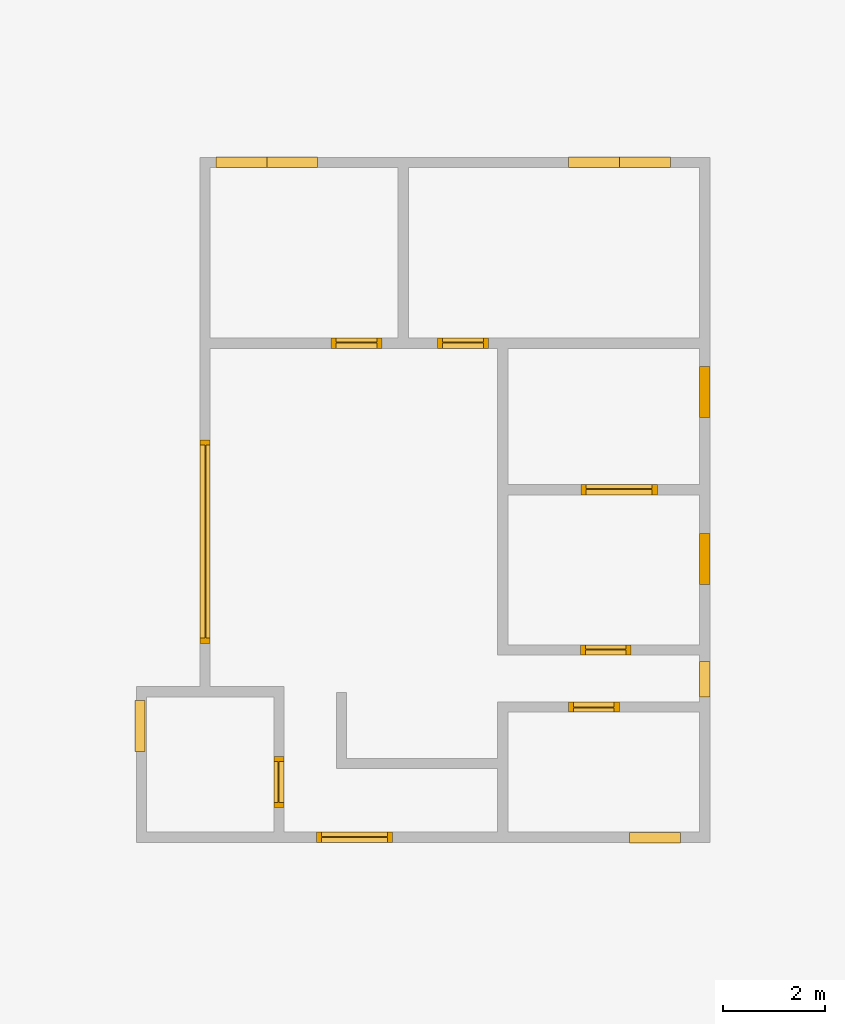
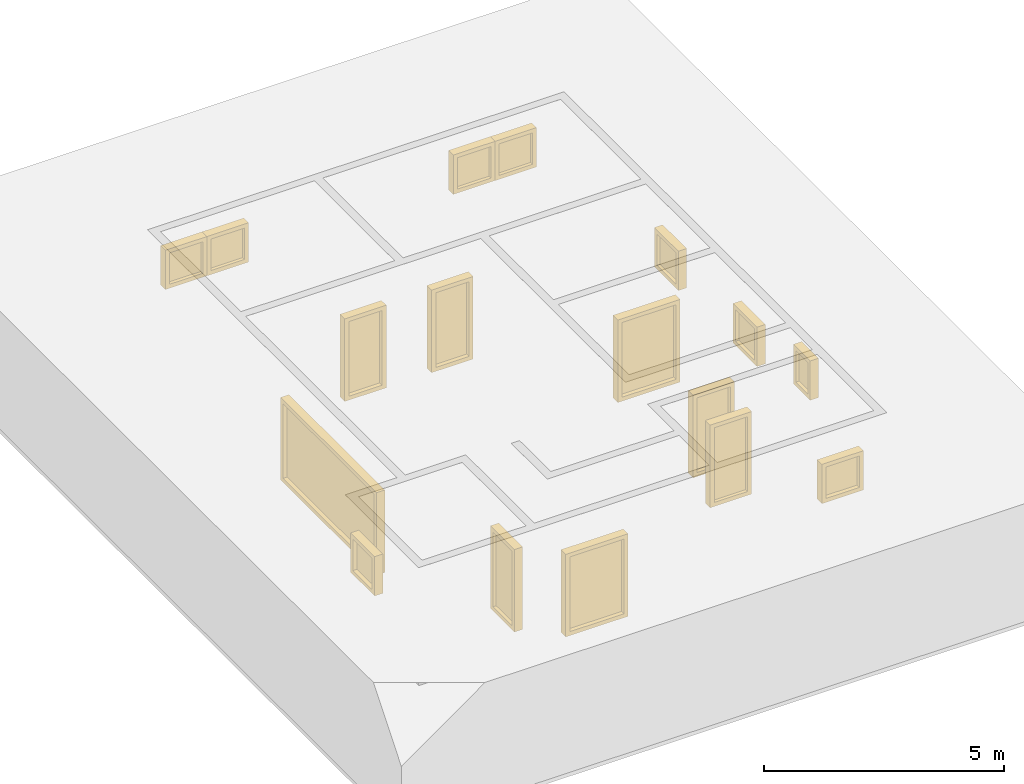
# Not in any storey, part 2 of 2: 17 windows.
"""IFC4 building model written with IfcOpenShell, lengths in metres."""

import ifcopenshell
import ifcopenshell.guid

model = None  # the IFC model being written
_history = None  # IfcOwnerHistory: only IFC2X3 demands one
_inside = {}  # id of a spatial element -> (the spatial element, [elements in it])
_under = {}  # id of a project, library or spatial element -> (it, [spatial elements below it])
_declared = {}  # id of a project -> (the project, [libraries it declares])
_typed = {}  # id of a type object -> (the type object, [elements of that type])
_made_of = {}  # id of a material, layer set ... -> (it, [elements and type objects made of it])


def new_model(schema):
    """Start an empty IFC model of exactly this schema.

    Asked for "IFC4X3", IfcOpenShell would pick the latest addendum, in which some entities
    have other attributes; the version numbers below select the first issue.
    IFC2X3 requires an IfcOwnerHistory on every rooted entity: one is made here for all.
    """
    global model, _history
    if schema == "IFC4X3":
        model = ifcopenshell.file(schema_version=(4, 3, 0, 0))
    else:
        model = ifcopenshell.file(schema=schema)
    _inside.clear()
    _under.clear()
    _declared.clear()
    _typed.clear()
    _made_of.clear()
    _history = None
    if model.schema == "IFC2X3":
        org = make("IfcOrganization", Name="unknown")
        user = make(
            "IfcPersonAndOrganization",
            ThePerson=make("IfcPerson", FamilyName="unknown"),
            TheOrganization=org,
        )
        app = make(
            "IfcApplication",
            ApplicationDeveloper=org,
            Version="unknown",
            ApplicationFullName="unknown",
            ApplicationIdentifier="unknown",
        )
        _history = make(
            "IfcOwnerHistory",
            OwningUser=user,
            OwningApplication=app,
            ChangeAction="ADDED",
            CreationDate=0,
        )
    return model


def make(cls, **values):
    """One entity of the class cls with the attributes given. An attribute that is None is left unset."""
    return model.create_entity(
        cls, **{name: value for name, value in values.items() if value is not None}
    )


def entity(cls, *values):
    """Any entity or typed value of the class cls, its attributes in the order of the schema. None: left unset."""
    e = model.create_entity(cls)
    for i, value in enumerate(values):
        if value is not None:
            e[i] = value
    return e


def rooted(cls, **values):
    """An entity with a GlobalId (a new one), such as an element, a storey or a relation."""
    return make(cls, GlobalId=ifcopenshell.guid.new(), OwnerHistory=_history, **values)


def si_unit(unit_type, name, prefix=None):
    """IfcSIUnit, for example si_unit("LENGTHUNIT", "METRE", prefix="MILLI")."""
    return make("IfcSIUnit", UnitType=unit_type, Prefix=prefix, Name=name)


def converted_unit(unit_type, name, factor, base, dimensions=None, offset=None):
    """IfcConversionBasedUnit, such as the inch: factor (a typed value) times the base unit."""
    return make(
        "IfcConversionBasedUnit"
        if offset is None
        else "IfcConversionBasedUnitWithOffset",
        ConversionOffset=offset,
        Dimensions=None
        if dimensions is None
        else entity("IfcDimensionalExponents", *dimensions),
        UnitType=unit_type,
        Name=name,
        ConversionFactor=make(
            "IfcMeasureWithUnit", ValueComponent=factor, UnitComponent=base
        ),
    )


def assignment(units):
    """IfcUnitAssignment: the units of a project."""
    return None if units is None else make("IfcUnitAssignment", Units=units)


def point(xyz):
    """IfcCartesianPoint."""
    return None if xyz is None else make("IfcCartesianPoint", Coordinates=xyz)


def direction(xyz):
    """IfcDirection."""
    return None if xyz is None else make("IfcDirection", DirectionRatios=xyz)


def frame(location, z_axis=None, x_axis=None):
    """IfcAxis2Placement3D, a coordinate frame: its origin and axes. An axis left out is left unset."""
    return make(
        "IfcAxis2Placement3D",
        Location=point(location),
        Axis=direction(z_axis),
        RefDirection=direction(x_axis),
    )


def origin_with_axes():
    """The frame at (0, 0, 0) with the z axis (0, 0, 1) and the x axis (1, 0, 0) written out."""
    return frame((0.0, 0.0, 0.0), z_axis=(0.0, 0.0, 1.0), x_axis=(1.0, 0.0, 0.0))


def place(relative_to, where):
    """IfcLocalPlacement: puts the frame where relative to a parent placement (None: the world)."""
    return make(
        "IfcLocalPlacement", PlacementRelTo=relative_to, RelativePlacement=where
    )


def context(
    kind, dimensions, precision=None, world=None, true_north=None, identifier=None
):
    """IfcGeometricRepresentationContext, for example the 3D "Model" context."""
    return make(
        "IfcGeometricRepresentationContext",
        ContextIdentifier=identifier,
        ContextType=kind,
        CoordinateSpaceDimension=dimensions,
        Precision=precision,
        WorldCoordinateSystem=world,
        TrueNorth=true_north,
    )


def subcontext(parent, identifier, kind, view, scale=None):
    """IfcGeometricRepresentationSubContext, for example "Body" below "Model"."""
    return make(
        "IfcGeometricRepresentationSubContext",
        ContextIdentifier=identifier,
        ContextType=kind,
        ParentContext=parent,
        TargetScale=scale,
        TargetView=view,
    )


def project(units=None, contexts=None):
    """IfcProject with its units and contexts."""
    return rooted(
        "IfcProject",
        Name="project",
        RepresentationContexts=contexts,
        UnitsInContext=assignment(units),
    )


def spatial(cls, under=None, at=None, **own):
    """A site, building, storey or space (cls), placed at a placement, below another one or the project."""
    s = rooted(cls, ObjectPlacement=at, **own)
    if under is not None:
        _under.setdefault(under.id(), (under, []))[1].append(s)
    return s


def faces_of(points, faces, orient=None, outer=None):
    """IfcFace entities. A face is a list of loops; a loop is a list of indices into points, from 0.

    orient and outer hold one flag for each loop. By default every Orientation is true, the
    first loop of a face is its IfcFaceOuterBound and the others are IfcFaceBound.
    """
    made = []
    for i, loops in enumerate(faces):
        bounds = []
        for j, loop in enumerate(loops):
            is_outer = j == 0 if outer is None else outer[i][j]
            bounds.append(
                make(
                    "IfcFaceOuterBound" if is_outer else "IfcFaceBound",
                    Bound=make("IfcPolyLoop", Polygon=[points[k] for k in loop]),
                    Orientation=True if orient is None else orient[i][j],
                )
            )
        made.append(make("IfcFace", Bounds=bounds))
    return made


def faceted_brep(points, faces, orient=None, outer=None, voids=None):
    """IfcFacetedBrep: a solid bounded by flat faces; with voids (closed shells), ...WithVoids."""
    shared = [point(p) for p in points]
    hull = make("IfcClosedShell", CfsFaces=faces_of(shared, faces, orient, outer))
    if voids is None:
        return make("IfcFacetedBrep", Outer=hull)
    return make(
        "IfcFacetedBrepWithVoids",
        Outer=hull,
        Voids=[
            make(cls, CfsFaces=faces_of(shared, fs, o, b)) for cls, fs, o, b in voids
        ],
    )


def shape(context_of_items, identifier, shape_type, items):
    """IfcShapeRepresentation: the items that make up one representation, for example the "Body"."""
    return make(
        "IfcShapeRepresentation",
        ContextOfItems=context_of_items,
        RepresentationIdentifier=identifier,
        RepresentationType=shape_type,
        Items=items,
    )


def made_of(thing, what):
    """Note that an element or type object is made of a material, layer set ...; save() writes the relation."""
    if what is not None:
        _made_of.setdefault(what.id(), (what, []))[1].append(thing)
    return thing


def element(
    cls,
    number,
    at=None,
    inside=None,
    cuts=None,
    type_object=None,
    material=None,
    context=None,
    identifier="Body",
    shape_type=None,
    held_by="IfcProductDefinitionShape",
    body=None,
    shapes=None,
    **own,
):
    """One element of the class cls, such as IfcWall. Its Tag is "e" and its number.

    at: its placement. inside: the storey or other place that contains it. cuts: it is an
    opening in that element (IfcRelVoidsElement). A single representation is given by context,
    identifier, shape_type and body (its items); several are given by shapes. held_by: the class
    of the entity that holds the representations. save() writes the other relations.
    """
    e = rooted(cls, Tag="e%d" % number, ObjectPlacement=at, **own)
    if body is not None:
        shapes = [shape(context, identifier, shape_type, body)]
    if shapes is not None:
        e.Representation = make(held_by, Representations=shapes)
    if inside is not None:
        _inside.setdefault(inside.id(), (inside, []))[1].append(e)
    if cuts is not None:
        rooted(
            "IfcRelVoidsElement", RelatingBuildingElement=cuts, RelatedOpeningElement=e
        )
    if type_object is not None:
        _typed.setdefault(type_object.id(), (type_object, []))[1].append(e)
    return made_of(e, material)


def aggregate(whole, parts):
    """IfcRelAggregates: a whole, such as a stair, and the parts it consists of."""
    return rooted("IfcRelAggregates", RelatingObject=whole, RelatedObjects=parts)


def save(model, path):
    """Write the relations noted so far, then the file.

    IfcRelAggregates (storeys below a building ...), IfcRelContainedInSpatialStructure (elements
    in a storey), IfcRelDefinesByType, IfcRelAssociatesMaterial and IfcRelDeclares: one each for
    every whole, place, type object, material and project.
    """
    for whole, parts in _under.values():
        aggregate(whole, parts)
    for where, things in _inside.values():
        rooted(
            "IfcRelContainedInSpatialStructure",
            RelatedElements=things,
            RelatingStructure=where,
        )
    for kind, things in _typed.values():
        rooted("IfcRelDefinesByType", RelatedObjects=things, RelatingType=kind)
    for what, things in _made_of.values():
        rooted("IfcRelAssociatesMaterial", RelatedObjects=things, RelatingMaterial=what)
    for by, libraries in _declared.values():
        rooted("IfcRelDeclares", RelatingContext=by, RelatedDefinitions=libraries)
    model.write(path)


model = new_model("IFC4")

# Units and contexts
model_context = context("Model", 3, precision=1e-05, world=origin_with_axes(), true_north=direction((0.0, 1.0)))
body_context = subcontext(model_context, "Body", "Model", "MODEL_VIEW")
ifc_project = project(units=[si_unit("LENGTHUNIT", "METRE"), si_unit("AREAUNIT", "SQUARE_METRE"), si_unit("VOLUMEUNIT", "CUBIC_METRE"), converted_unit("PLANEANGLEUNIT", "DEGREE", entity("IfcPlaneAngleMeasure", 0.017453292519943295), si_unit("PLANEANGLEUNIT", "RADIAN"), dimensions=[0, 0, 0, 0, 0, 0, 0])], contexts=[model_context])

# Building
building = spatial("IfcBuilding", Name="002", CompositionType="COMPLEX")

# Windows
placement = place(None, origin_with_axes())
element("IfcWindow", 1, at=placement, inside=building, Name="006", OverallHeight=2100.0, OverallWidth=1000.0, PartitioningType="SINGLE_PANEL", PredefinedType="WINDOW", context=body_context, shape_type="Brep", body=[
    faceted_brep([(2.799520508, -1.01211743164062, 0.0), (2.599520508, -1.01211743164062, 0.0), (2.599520508, -0.012117431640625, 0.0), (2.799520508, -0.012117431640625, 0.0), (2.799520508, -1.01211743164062, 2.1), (2.599520508, -1.01211743164062, 2.1), (2.599520508, -0.012117431640625, 2.1), (2.799520508, -0.012117431640625, 2.1), (2.799520508, -0.112117431640625, 0.1), (2.799520508, -0.912117431640625, 0.1), (2.799520508, -0.912117431640625, 2.0), (2.799520508, -0.112117431640625, 2.0), (2.599520508, -0.912117431640625, 0.1), (2.599520508, -0.112117431640625, 0.1), (2.599520508, -0.112117431640625, 2.0), (2.599520508, -0.912117431640625, 2.0)], [[[0, 1, 2, 3]], [[4, 5, 1, 0]], [[3, 2, 6, 7]], [[0, 3, 7, 4], [8, 9, 10, 11]], [[5, 6, 2, 1], [12, 13, 14, 15]], [[7, 6, 5, 4]], [[8, 13, 12, 9]], [[11, 14, 13, 8]], [[10, 15, 14, 11]], [[9, 12, 15, 10]]]),
    faceted_brep([(2.699520508, -0.912117431640625, 0.1), (2.679520508, -0.912117431640625, 0.1), (2.679520508, -0.112117431640625, 0.1), (2.699520508, -0.112117431640625, 0.1), (2.679520508, -0.112117431640625, 2.0), (2.699520508, -0.112117431640625, 2.0), (2.679520508, -0.912117431640625, 2.0), (2.699520508, -0.912117431640625, 2.0)], [[[0, 1, 2, 3]], [[3, 2, 4, 5]], [[5, 4, 6, 7]], [[7, 6, 1, 0]], [[0, 3, 5, 7]], [[6, 4, 2, 1]]]),
])
element("IfcWindow", 2, at=placement, inside=building, Name="009", OverallHeight=2100.0, OverallWidth=1000.0, PartitioningType="SINGLE_PANEL", PredefinedType="WINDOW", context=body_context, shape_type="Brep", body=[
    faceted_brep([(3.7253876953125, 8.00997583, 0.0), (3.7253876953125, 8.20997583, -4e-17), (4.7253876953125, 8.20997583, -4e-17), (4.7253876953125, 8.00997583, 0.0), (3.7253876953125, 8.00997583, 2.1), (3.7253876953125, 8.20997583, 2.1), (4.7253876953125, 8.20997583, 2.1), (4.7253876953125, 8.00997583, 2.1), (4.6253876953125, 8.00997583, 0.1), (3.8253876953125, 8.00997583, 0.1), (3.8253876953125, 8.00997583, 2.0), (4.6253876953125, 8.00997583, 2.0), (3.8253876953125, 8.20997583, 0.1), (4.6253876953125, 8.20997583, 0.1), (4.6253876953125, 8.20997583, 2.0), (3.8253876953125, 8.20997583, 2.0)], [[[0, 1, 2, 3]], [[4, 5, 1, 0]], [[3, 2, 6, 7]], [[0, 3, 7, 4], [8, 9, 10, 11]], [[5, 6, 2, 1], [12, 13, 14, 15]], [[7, 6, 5, 4]], [[8, 13, 12, 9]], [[11, 14, 13, 8]], [[10, 15, 14, 11]], [[9, 12, 15, 10]]]),
    faceted_brep([(3.8253876953125, 8.10997583, 0.1), (3.8253876953125, 8.12997583, 0.1), (4.6253876953125, 8.12997583, 0.1), (4.6253876953125, 8.10997583, 0.1), (4.6253876953125, 8.12997583, 2.0), (4.6253876953125, 8.10997583, 2.0), (3.8253876953125, 8.12997583, 2.0), (3.8253876953125, 8.10997583, 2.0)], [[[0, 1, 2, 3]], [[3, 2, 4, 5]], [[5, 4, 6, 7]], [[7, 6, 1, 0]], [[0, 3, 5, 7]], [[6, 4, 2, 1]]]),
])
element("IfcWindow", 3, at=placement, inside=building, Name="010", OverallHeight=1000.0, OverallWidth=1000.0, PartitioningType="SINGLE_PANEL", PredefinedType="WINDOW", context=body_context, shape_type="Brep", body=[
    faceted_brep([(3.46358325195312, 11.766516357, 1.48285754394531), (3.46358325195312, 11.566516357, 1.48285754394531), (2.46358325195312, 11.566516357, 1.48285754394531), (2.46358325195312, 11.766516357, 1.48285754394531), (3.46358325195312, 11.766516357, 2.48285754394531), (3.46358325195312, 11.566516357, 2.48285754394531), (2.46358325195312, 11.566516357, 2.48285754394531), (2.46358325195312, 11.766516357, 2.48285754394531), (2.56358325195312, 11.766516357, 1.58285754394531), (3.36358325195313, 11.766516357, 1.58285754394531), (3.36358325195313, 11.766516357, 2.38285754394531), (2.56358325195312, 11.766516357, 2.38285754394531), (3.36358325195313, 11.566516357, 1.58285754394531), (2.56358325195312, 11.566516357, 1.58285754394531), (2.56358325195312, 11.566516357, 2.38285754394531), (3.36358325195313, 11.566516357, 2.38285754394531)], [[[0, 1, 2, 3]], [[4, 5, 1, 0]], [[3, 2, 6, 7]], [[0, 3, 7, 4], [8, 9, 10, 11]], [[5, 6, 2, 1], [12, 13, 14, 15]], [[7, 6, 5, 4]], [[8, 13, 12, 9]], [[11, 14, 13, 8]], [[10, 15, 14, 11]], [[9, 12, 15, 10]]]),
    faceted_brep([(3.36358325195313, 11.666516357, 1.58285754394531), (3.36358325195313, 11.646516357, 1.58285754394531), (2.56358325195312, 11.646516357, 1.58285754394531), (2.56358325195312, 11.666516357, 1.58285754394531), (2.56358325195312, 11.646516357, 2.38285754394531), (2.56358325195312, 11.666516357, 2.38285754394531), (3.36358325195313, 11.646516357, 2.38285754394531), (3.36358325195313, 11.666516357, 2.38285754394531)], [[[0, 1, 2, 3]], [[3, 2, 4, 5]], [[5, 4, 6, 7]], [[7, 6, 1, 0]], [[0, 3, 5, 7]], [[6, 4, 2, 1]]]),
])
element("IfcWindow", 4, at=placement, inside=building, Name="011", OverallHeight=1000.0, OverallWidth=1000.0, PartitioningType="SINGLE_PANEL", PredefinedType="WINDOW", context=body_context, shape_type="Brep", body=[
    faceted_brep([(2.46358325195312, 11.766516357, 1.48285754394531), (2.46358325195312, 11.566516357, 1.48285754394531), (1.46358325195313, 11.566516357, 1.48285754394531), (1.46358325195313, 11.766516357, 1.48285754394531), (2.46358325195312, 11.766516357, 2.48285754394531), (2.46358325195312, 11.566516357, 2.48285754394531), (1.46358325195313, 11.566516357, 2.48285754394531), (1.46358325195313, 11.766516357, 2.48285754394531), (1.56358325195312, 11.766516357, 1.58285754394531), (2.36358325195313, 11.766516357, 1.58285754394531), (2.36358325195313, 11.766516357, 2.38285754394531), (1.56358325195312, 11.766516357, 2.38285754394531), (2.36358325195313, 11.566516357, 1.58285754394531), (1.56358325195312, 11.566516357, 1.58285754394531), (1.56358325195312, 11.566516357, 2.38285754394531), (2.36358325195313, 11.566516357, 2.38285754394531)], [[[0, 1, 2, 3]], [[4, 5, 1, 0]], [[3, 2, 6, 7]], [[0, 3, 7, 4], [8, 9, 10, 11]], [[5, 6, 2, 1], [12, 13, 14, 15]], [[7, 6, 5, 4]], [[8, 13, 12, 9]], [[11, 14, 13, 8]], [[10, 15, 14, 11]], [[9, 12, 15, 10]]]),
    faceted_brep([(2.36358325195313, 11.666516357, 1.58285754394531), (2.36358325195313, 11.646516357, 1.58285754394531), (1.56358325195312, 11.646516357, 1.58285754394531), (1.56358325195312, 11.666516357, 1.58285754394531), (1.56358325195312, 11.646516357, 2.38285754394531), (1.56358325195312, 11.666516357, 2.38285754394531), (2.36358325195313, 11.646516357, 2.38285754394531), (2.36358325195313, 11.666516357, 2.38285754394531)], [[[0, 1, 2, 3]], [[3, 2, 4, 5]], [[5, 4, 6, 7]], [[7, 6, 1, 0]], [[0, 3, 5, 7]], [[6, 4, 2, 1]]]),
])
element("IfcWindow", 5, at=placement, inside=building, Name="012", OverallHeight=1000.0, OverallWidth=1000.0, PartitioningType="SINGLE_PANEL", PredefinedType="WINDOW", context=body_context, shape_type="Brep", body=[
    faceted_brep([(10.394705078125, 11.766516357, 1.477650390625), (10.394705078125, 11.566516357, 1.477650390625), (9.394705078125, 11.566516357, 1.477650390625), (9.394705078125, 11.766516357, 1.477650390625), (10.394705078125, 11.766516357, 2.477650390625), (10.394705078125, 11.566516357, 2.477650390625), (9.394705078125, 11.566516357, 2.477650390625), (9.394705078125, 11.766516357, 2.477650390625), (9.494705078125, 11.766516357, 1.577650390625), (10.294705078125, 11.766516357, 1.577650390625), (10.294705078125, 11.766516357, 2.377650390625), (9.494705078125, 11.766516357, 2.377650390625), (10.294705078125, 11.566516357, 1.577650390625), (9.494705078125, 11.566516357, 1.577650390625), (9.494705078125, 11.566516357, 2.377650390625), (10.294705078125, 11.566516357, 2.377650390625)], [[[0, 1, 2, 3]], [[4, 5, 1, 0]], [[3, 2, 6, 7]], [[0, 3, 7, 4], [8, 9, 10, 11]], [[5, 6, 2, 1], [12, 13, 14, 15]], [[7, 6, 5, 4]], [[8, 13, 12, 9]], [[11, 14, 13, 8]], [[10, 15, 14, 11]], [[9, 12, 15, 10]]]),
    faceted_brep([(10.294705078125, 11.666516357, 1.577650390625), (10.294705078125, 11.646516357, 1.577650390625), (9.494705078125, 11.646516357, 1.577650390625), (9.494705078125, 11.666516357, 1.577650390625), (9.494705078125, 11.646516357, 2.377650390625), (9.494705078125, 11.666516357, 2.377650390625), (10.294705078125, 11.646516357, 2.377650390625), (10.294705078125, 11.666516357, 2.377650390625)], [[[0, 1, 2, 3]], [[3, 2, 4, 5]], [[5, 4, 6, 7]], [[7, 6, 1, 0]], [[0, 3, 5, 7]], [[6, 4, 2, 1]]]),
])
element("IfcWindow", 6, at=placement, inside=building, Name="013", OverallHeight=1000.0, OverallWidth=1000.0, PartitioningType="SINGLE_PANEL", PredefinedType="WINDOW", context=body_context, shape_type="Brep", body=[
    faceted_brep([(9.394705078125, 11.766516357, 1.477650390625), (9.394705078125, 11.566516357, 1.477650390625), (8.394705078125, 11.566516357, 1.477650390625), (8.394705078125, 11.766516357, 1.477650390625), (9.394705078125, 11.766516357, 2.477650390625), (9.394705078125, 11.566516357, 2.477650390625), (8.394705078125, 11.566516357, 2.477650390625), (8.394705078125, 11.766516357, 2.477650390625), (8.494705078125, 11.766516357, 1.577650390625), (9.294705078125, 11.766516357, 1.577650390625), (9.294705078125, 11.766516357, 2.377650390625), (8.494705078125, 11.766516357, 2.377650390625), (9.294705078125, 11.566516357, 1.577650390625), (8.494705078125, 11.566516357, 1.577650390625), (8.494705078125, 11.566516357, 2.377650390625), (9.294705078125, 11.566516357, 2.377650390625)], [[[0, 1, 2, 3]], [[4, 5, 1, 0]], [[3, 2, 6, 7]], [[0, 3, 7, 4], [8, 9, 10, 11]], [[5, 6, 2, 1], [12, 13, 14, 15]], [[7, 6, 5, 4]], [[8, 13, 12, 9]], [[11, 14, 13, 8]], [[10, 15, 14, 11]], [[9, 12, 15, 10]]]),
    faceted_brep([(9.294705078125, 11.666516357, 1.577650390625), (9.294705078125, 11.646516357, 1.577650390625), (8.494705078125, 11.646516357, 1.577650390625), (8.494705078125, 11.666516357, 1.577650390625), (8.494705078125, 11.646516357, 2.377650390625), (8.494705078125, 11.666516357, 2.377650390625), (9.294705078125, 11.646516357, 2.377650390625), (9.294705078125, 11.666516357, 2.377650390625)], [[[0, 1, 2, 3]], [[3, 2, 4, 5]], [[5, 4, 6, 7]], [[7, 6, 1, 0]], [[0, 3, 5, 7]], [[6, 4, 2, 1]]]),
])
element("IfcWindow", 7, at=placement, inside=building, Name="014", OverallHeight=1000.0, OverallWidth=1000.0, PartitioningType="SINGLE_PANEL", PredefinedType="WINDOW", context=body_context, shape_type="Brep", body=[
    faceted_brep([(-0.127817366, 1.09050927734375, 1.20494030761719), (0.072182634, 1.09050927734375, 1.20494030761719), (0.072182634, 0.09050927734375, 1.20494030761719), (-0.127817366, 0.09050927734375, 1.20494030761719), (-0.127817366, 1.09050927734375, 2.20494030761719), (0.072182634, 1.09050927734375, 2.20494030761719), (0.072182634, 0.09050927734375, 2.20494030761719), (-0.127817366, 0.09050927734375, 2.20494030761719), (-0.127817366, 0.19050927734375, 1.30494030761719), (-0.127817366, 0.99050927734375, 1.30494030761719), (-0.127817366, 0.99050927734375, 2.10494030761719), (-0.127817366, 0.19050927734375, 2.10494030761719), (0.072182634, 0.99050927734375, 1.30494030761719), (0.072182634, 0.19050927734375, 1.30494030761719), (0.072182634, 0.19050927734375, 2.10494030761719), (0.072182634, 0.99050927734375, 2.10494030761719)], [[[0, 1, 2, 3]], [[4, 5, 1, 0]], [[3, 2, 6, 7]], [[0, 3, 7, 4], [8, 9, 10, 11]], [[5, 6, 2, 1], [12, 13, 14, 15]], [[7, 6, 5, 4]], [[8, 13, 12, 9]], [[11, 14, 13, 8]], [[10, 15, 14, 11]], [[9, 12, 15, 10]]]),
    faceted_brep([(-0.027817366, 0.99050927734375, 1.30494030761719), (-0.00781736599999999, 0.99050927734375, 1.30494030761719), (-0.00781736599999999, 0.19050927734375, 1.30494030761719), (-0.027817366, 0.19050927734375, 1.30494030761719), (-0.00781736599999999, 0.19050927734375, 2.10494030761719), (-0.027817366, 0.19050927734375, 2.10494030761719), (-0.00781736599999999, 0.99050927734375, 2.10494030761719), (-0.027817366, 0.99050927734375, 2.10494030761719)], [[[0, 1, 2, 3]], [[3, 2, 4, 5]], [[5, 4, 6, 7]], [[7, 6, 1, 0]], [[0, 3, 5, 7]], [[6, 4, 2, 1]]]),
])
element("IfcWindow", 8, at=placement, inside=building, Name="015", OverallHeight=1000.0, OverallWidth=1000.0, PartitioningType="SINGLE_PANEL", PredefinedType="WINDOW", context=body_context, shape_type="Brep", body=[
    faceted_brep([(9.595484375, -1.709431519, 1.23817114257812), (9.595484375, -1.509431519, 1.23817114257812), (10.595484375, -1.509431519, 1.23817114257812), (10.595484375, -1.709431519, 1.23817114257812), (9.595484375, -1.709431519, 2.23817114257813), (9.595484375, -1.509431519, 2.23817114257813), (10.595484375, -1.509431519, 2.23817114257813), (10.595484375, -1.709431519, 2.23817114257813), (10.495484375, -1.709431519, 1.33817114257813), (9.695484375, -1.709431519, 1.33817114257813), (9.695484375, -1.709431519, 2.13817114257813), (10.495484375, -1.709431519, 2.13817114257813), (9.695484375, -1.509431519, 1.33817114257813), (10.495484375, -1.509431519, 1.33817114257813), (10.495484375, -1.509431519, 2.13817114257813), (9.695484375, -1.509431519, 2.13817114257813)], [[[0, 1, 2, 3]], [[4, 5, 1, 0]], [[3, 2, 6, 7]], [[0, 3, 7, 4], [8, 9, 10, 11]], [[5, 6, 2, 1], [12, 13, 14, 15]], [[7, 6, 5, 4]], [[8, 13, 12, 9]], [[11, 14, 13, 8]], [[10, 15, 14, 11]], [[9, 12, 15, 10]]]),
    faceted_brep([(9.695484375, -1.609431519, 1.33817114257813), (9.695484375, -1.589431519, 1.33817114257813), (10.495484375, -1.589431519, 1.33817114257813), (10.495484375, -1.609431519, 1.33817114257813), (10.495484375, -1.589431519, 2.13817114257813), (10.495484375, -1.609431519, 2.13817114257813), (9.695484375, -1.589431519, 2.13817114257813), (9.695484375, -1.609431519, 2.13817114257813)], [[[0, 1, 2, 3]], [[3, 2, 4, 5]], [[5, 4, 6, 7]], [[7, 6, 1, 0]], [[0, 3, 5, 7]], [[6, 4, 2, 1]]]),
])
element("IfcWindow", 9, at=placement, inside=building, Name="017", OverallHeight=2100.0, OverallWidth=1500.0, PartitioningType="SINGLE_PANEL", PredefinedType="WINDOW", context=body_context, shape_type="Brep", body=[
    faceted_brep([(8.63672265625, 5.131109375, 0.0), (8.63672265625, 5.331109375, -4e-17), (10.13672265625, 5.331109375, -4e-17), (10.13672265625, 5.131109375, 0.0), (8.63672265625, 5.131109375, 2.1), (8.63672265625, 5.331109375, 2.1), (10.13672265625, 5.331109375, 2.1), (10.13672265625, 5.131109375, 2.1), (10.03672265625, 5.131109375, 0.1), (8.73672265625, 5.131109375, 0.1), (8.73672265625, 5.131109375, 2.0), (10.03672265625, 5.131109375, 2.0), (8.73672265625, 5.331109375, 0.1), (10.03672265625, 5.331109375, 0.1), (10.03672265625, 5.331109375, 2.0), (8.73672265625, 5.331109375, 2.0)], [[[0, 1, 2, 3]], [[4, 5, 1, 0]], [[3, 2, 6, 7]], [[0, 3, 7, 4], [8, 9, 10, 11]], [[5, 6, 2, 1], [12, 13, 14, 15]], [[7, 6, 5, 4]], [[8, 13, 12, 9]], [[11, 14, 13, 8]], [[10, 15, 14, 11]], [[9, 12, 15, 10]]]),
    faceted_brep([(8.73672265625, 5.231109375, 0.1), (8.73672265625, 5.251109375, 0.1), (10.03672265625, 5.251109375, 0.1), (10.03672265625, 5.231109375, 0.1), (10.03672265625, 5.251109375, 2.0), (10.03672265625, 5.231109375, 2.0), (8.73672265625, 5.251109375, 2.0), (8.73672265625, 5.231109375, 2.0)], [[[0, 1, 2, 3]], [[3, 2, 4, 5]], [[5, 4, 6, 7]], [[7, 6, 1, 0]], [[0, 3, 5, 7]], [[6, 4, 2, 1]]]),
])
element("IfcWindow", 10, at=placement, inside=building, Name="018", OverallHeight=1000.0, OverallWidth=1000.0, PartitioningType="SINGLE_PANEL", PredefinedType="WINDOW", context=body_context, shape_type="Brep", body=[
    faceted_brep([(11.170980469, 3.37278393554688, 1.16492016601562), (10.970980469, 3.37278393554688, 1.16492016601562), (10.970980469, 4.37278393554687, 1.16492016601562), (11.170980469, 4.37278393554687, 1.16492016601562), (11.170980469, 3.37278393554688, 2.16492016601563), (10.970980469, 3.37278393554688, 2.16492016601563), (10.970980469, 4.37278393554687, 2.16492016601563), (11.170980469, 4.37278393554687, 2.16492016601563), (11.170980469, 4.27278393554688, 1.26492016601563), (11.170980469, 3.47278393554688, 1.26492016601563), (11.170980469, 3.47278393554688, 2.06492016601563), (11.170980469, 4.27278393554688, 2.06492016601563), (10.970980469, 3.47278393554688, 1.26492016601563), (10.970980469, 4.27278393554688, 1.26492016601563), (10.970980469, 4.27278393554688, 2.06492016601563), (10.970980469, 3.47278393554688, 2.06492016601563)], [[[0, 1, 2, 3]], [[4, 5, 1, 0]], [[3, 2, 6, 7]], [[0, 3, 7, 4], [8, 9, 10, 11]], [[5, 6, 2, 1], [12, 13, 14, 15]], [[7, 6, 5, 4]], [[8, 13, 12, 9]], [[11, 14, 13, 8]], [[10, 15, 14, 11]], [[9, 12, 15, 10]]]),
    faceted_brep([(11.070980469, 3.47278393554688, 1.26492016601563), (11.050980469, 3.47278393554688, 1.26492016601563), (11.050980469, 4.27278393554688, 1.26492016601563), (11.070980469, 4.27278393554688, 1.26492016601563), (11.050980469, 4.27278393554688, 2.06492016601563), (11.070980469, 4.27278393554688, 2.06492016601563), (11.050980469, 3.47278393554688, 2.06492016601563), (11.070980469, 3.47278393554688, 2.06492016601563)], [[[0, 1, 2, 3]], [[3, 2, 4, 5]], [[5, 4, 6, 7]], [[7, 6, 1, 0]], [[0, 3, 5, 7]], [[6, 4, 2, 1]]]),
])
element("IfcWindow", 11, at=placement, inside=building, Name="019", OverallHeight=1000.0, OverallWidth=1000.0, PartitioningType="SINGLE_PANEL", PredefinedType="WINDOW", context=body_context, shape_type="Brep", body=[
    faceted_brep([(11.170980469, 6.6536171875, 1.10756701660156), (10.970980469, 6.6536171875, 1.10756701660156), (10.970980469, 7.6536171875, 1.10756701660156), (11.170980469, 7.6536171875, 1.10756701660156), (11.170980469, 6.6536171875, 2.10756701660156), (10.970980469, 6.6536171875, 2.10756701660156), (10.970980469, 7.6536171875, 2.10756701660156), (11.170980469, 7.6536171875, 2.10756701660156), (11.170980469, 7.5536171875, 1.20756701660156), (11.170980469, 6.7536171875, 1.20756701660156), (11.170980469, 6.7536171875, 2.00756701660156), (11.170980469, 7.5536171875, 2.00756701660156), (10.970980469, 6.7536171875, 1.20756701660156), (10.970980469, 7.5536171875, 1.20756701660156), (10.970980469, 7.5536171875, 2.00756701660156), (10.970980469, 6.7536171875, 2.00756701660156)], [[[0, 1, 2, 3]], [[4, 5, 1, 0]], [[3, 2, 6, 7]], [[0, 3, 7, 4], [8, 9, 10, 11]], [[5, 6, 2, 1], [12, 13, 14, 15]], [[7, 6, 5, 4]], [[8, 13, 12, 9]], [[11, 14, 13, 8]], [[10, 15, 14, 11]], [[9, 12, 15, 10]]]),
    faceted_brep([(11.070980469, 6.7536171875, 1.20756701660156), (11.050980469, 6.7536171875, 1.20756701660156), (11.050980469, 7.5536171875, 1.20756701660156), (11.070980469, 7.5536171875, 1.20756701660156), (11.050980469, 7.5536171875, 2.00756701660156), (11.070980469, 7.5536171875, 2.00756701660156), (11.050980469, 6.7536171875, 2.00756701660156), (11.070980469, 6.7536171875, 2.00756701660156)], [[[0, 1, 2, 3]], [[3, 2, 4, 5]], [[5, 4, 6, 7]], [[7, 6, 1, 0]], [[0, 3, 5, 7]], [[6, 4, 2, 1]]]),
])
element("IfcWindow", 12, at=placement, inside=building, OverallHeight=1000.0, OverallWidth=700.0, PartitioningType="SINGLE_PANEL", PredefinedType="WINDOW", context=body_context, shape_type="Brep", body=[
    faceted_brep([(11.170980469, 1.15942370605469, 1.64867785644531), (10.970980469, 1.15942370605469, 1.64867785644531), (10.970980469, 1.85942370605469, 1.64867785644531), (11.170980469, 1.85942370605469, 1.64867785644531), (11.170980469, 1.15942370605469, 2.64867785644531), (10.970980469, 1.15942370605469, 2.64867785644531), (10.970980469, 1.85942370605469, 2.64867785644531), (11.170980469, 1.85942370605469, 2.64867785644531), (11.170980469, 1.75942370605469, 1.74867785644531), (11.170980469, 1.25942370605469, 1.74867785644531), (11.170980469, 1.25942370605469, 2.54867785644531), (11.170980469, 1.75942370605469, 2.54867785644531), (10.970980469, 1.25942370605469, 1.74867785644531), (10.970980469, 1.75942370605469, 1.74867785644531), (10.970980469, 1.75942370605469, 2.54867785644531), (10.970980469, 1.25942370605469, 2.54867785644531)], [[[0, 1, 2, 3]], [[4, 5, 1, 0]], [[3, 2, 6, 7]], [[0, 3, 7, 4], [8, 9, 10, 11]], [[5, 6, 2, 1], [12, 13, 14, 15]], [[7, 6, 5, 4]], [[8, 13, 12, 9]], [[11, 14, 13, 8]], [[10, 15, 14, 11]], [[9, 12, 15, 10]]]),
    faceted_brep([(11.070980469, 1.25942370605469, 1.74867785644531), (11.050980469, 1.25942370605469, 1.74867785644531), (11.050980469, 1.75942370605469, 1.74867785644531), (11.070980469, 1.75942370605469, 1.74867785644531), (11.050980469, 1.75942370605469, 2.54867785644531), (11.070980469, 1.75942370605469, 2.54867785644531), (11.050980469, 1.25942370605469, 2.54867785644531), (11.070980469, 1.25942370605469, 2.54867785644531)], [[[0, 1, 2, 3]], [[3, 2, 4, 5]], [[5, 4, 6, 7]], [[7, 6, 1, 0]], [[0, 3, 5, 7]], [[6, 4, 2, 1]]]),
])
element("IfcWindow", 13, at=placement, inside=building, Name="020", OverallHeight=2100.0, OverallWidth=1500.0, PartitioningType="SINGLE_PANEL", PredefinedType="WINDOW", context=body_context, shape_type="Brep", body=[
    faceted_brep([(3.43684497070313, -1.7, 0.0), (3.43684497070313, -1.5, -4.4e-17), (4.93684497070312, -1.5, -4.4e-17), (4.93684497070312, -1.7, 0.0), (3.43684497070313, -1.7, 2.1), (3.43684497070313, -1.5, 2.1), (4.93684497070312, -1.5, 2.1), (4.93684497070312, -1.7, 2.1), (4.83684497070313, -1.7, 0.1), (3.53684497070312, -1.7, 0.1), (3.53684497070312, -1.7, 2.0), (4.83684497070313, -1.7, 2.0), (3.53684497070312, -1.5, 0.1), (4.83684497070313, -1.5, 0.1), (4.83684497070313, -1.5, 2.0), (3.53684497070312, -1.5, 2.0)], [[[0, 1, 2, 3]], [[4, 5, 1, 0]], [[3, 2, 6, 7]], [[0, 3, 7, 4], [8, 9, 10, 11]], [[5, 6, 2, 1], [12, 13, 14, 15]], [[7, 6, 5, 4]], [[8, 13, 12, 9]], [[11, 14, 13, 8]], [[10, 15, 14, 11]], [[9, 12, 15, 10]]]),
    faceted_brep([(3.53684497070312, -1.6, 0.1), (3.53684497070312, -1.58, 0.1), (4.83684497070313, -1.58, 0.1), (4.83684497070313, -1.6, 0.1), (4.83684497070313, -1.58, 2.0), (4.83684497070313, -1.6, 2.0), (3.53684497070312, -1.58, 2.0), (3.53684497070312, -1.6, 2.0)], [[[0, 1, 2, 3]], [[3, 2, 4, 5]], [[5, 4, 6, 7]], [[7, 6, 1, 0]], [[0, 3, 5, 7]], [[6, 4, 2, 1]]]),
])
element("IfcWindow", 14, at=placement, inside=building, Name="021", OverallHeight=2100.0, OverallWidth=1000.0, PartitioningType="SINGLE_PANEL", PredefinedType="WINDOW", context=body_context, shape_type="Brep", body=[
    faceted_brep([(8.6232451171875, 1.98, 0.0), (8.6232451171875, 2.18, -4.4e-17), (9.6232451171875, 2.18, -4.4e-17), (9.6232451171875, 1.98, 0.0), (8.6232451171875, 1.98, 2.1), (8.6232451171875, 2.18, 2.1), (9.6232451171875, 2.18, 2.1), (9.6232451171875, 1.98, 2.1), (9.5232451171875, 1.98, 0.1), (8.7232451171875, 1.98, 0.1), (8.7232451171875, 1.98, 2.0), (9.5232451171875, 1.98, 2.0), (8.7232451171875, 2.18, 0.1), (9.5232451171875, 2.18, 0.1), (9.5232451171875, 2.18, 2.0), (8.7232451171875, 2.18, 2.0)], [[[0, 1, 2, 3]], [[4, 5, 1, 0]], [[3, 2, 6, 7]], [[0, 3, 7, 4], [8, 9, 10, 11]], [[5, 6, 2, 1], [12, 13, 14, 15]], [[7, 6, 5, 4]], [[8, 13, 12, 9]], [[11, 14, 13, 8]], [[10, 15, 14, 11]], [[9, 12, 15, 10]]]),
    faceted_brep([(8.7232451171875, 2.08, 0.1), (8.7232451171875, 2.1, 0.1), (9.5232451171875, 2.1, 0.1), (9.5232451171875, 2.08, 0.1), (9.5232451171875, 2.1, 2.0), (9.5232451171875, 2.08, 2.0), (8.7232451171875, 2.1, 2.0), (8.7232451171875, 2.08, 2.0)], [[[0, 1, 2, 3]], [[3, 2, 4, 5]], [[5, 4, 6, 7]], [[7, 6, 1, 0]], [[0, 3, 5, 7]], [[6, 4, 2, 1]]]),
])
element("IfcWindow", 15, at=placement, inside=building, Name="007", OverallHeight=2100.0, OverallWidth=1000.0, PartitioningType="SINGLE_PANEL", PredefinedType="WINDOW", context=body_context, shape_type="Brep", body=[
    faceted_brep([(9.3892021484375, 1.059165588, 0.0), (9.3892021484375, 0.859165588, 4e-17), (8.3892021484375, 0.859165588, 4e-17), (8.3892021484375, 1.059165588, 0.0), (9.3892021484375, 1.059165588, 2.1), (9.3892021484375, 0.859165588, 2.1), (8.3892021484375, 0.859165588, 2.1), (8.3892021484375, 1.059165588, 2.1), (8.4892021484375, 1.059165588, 0.1), (9.2892021484375, 1.059165588, 0.1), (9.2892021484375, 1.059165588, 2.0), (8.4892021484375, 1.059165588, 2.0), (9.2892021484375, 0.859165588, 0.1), (8.4892021484375, 0.859165588, 0.1), (8.4892021484375, 0.859165588, 2.0), (9.2892021484375, 0.859165588, 2.0)], [[[0, 1, 2, 3]], [[4, 5, 1, 0]], [[3, 2, 6, 7]], [[0, 3, 7, 4], [8, 9, 10, 11]], [[5, 6, 2, 1], [12, 13, 14, 15]], [[7, 6, 5, 4]], [[8, 13, 12, 9]], [[11, 14, 13, 8]], [[10, 15, 14, 11]], [[9, 12, 15, 10]]]),
    faceted_brep([(9.2892021484375, 0.959165588, 0.1), (9.2892021484375, 0.939165588, 0.1), (8.4892021484375, 0.939165588, 0.1), (8.4892021484375, 0.959165588, 0.1), (8.4892021484375, 0.939165588, 2.0), (8.4892021484375, 0.959165588, 2.0), (9.2892021484375, 0.939165588, 2.0), (9.2892021484375, 0.959165588, 2.0)], [[[0, 1, 2, 3]], [[3, 2, 4, 5]], [[5, 4, 6, 7]], [[7, 6, 1, 0]], [[0, 3, 5, 7]], [[6, 4, 2, 1]]]),
])
element("IfcWindow", 16, at=placement, inside=building, Name="022", OverallHeight=2100.0, OverallWidth=1000.0, PartitioningType="SINGLE_PANEL", PredefinedType="WINDOW", context=body_context, shape_type="Brep", body=[
    faceted_brep([(5.81764013671875, 8.01, 0.0), (5.81764013671875, 8.21, -4.4e-17), (6.81764013671875, 8.21, -4.4e-17), (6.81764013671875, 8.01, 0.0), (5.81764013671875, 8.01, 2.1), (5.81764013671875, 8.21, 2.1), (6.81764013671875, 8.21, 2.1), (6.81764013671875, 8.01, 2.1), (6.71764013671875, 8.01, 0.1), (5.91764013671875, 8.01, 0.1), (5.91764013671875, 8.01, 2.0), (6.71764013671875, 8.01, 2.0), (5.91764013671875, 8.21, 0.1), (6.71764013671875, 8.21, 0.1), (6.71764013671875, 8.21, 2.0), (5.91764013671875, 8.21, 2.0)], [[[0, 1, 2, 3]], [[4, 5, 1, 0]], [[3, 2, 6, 7]], [[0, 3, 7, 4], [8, 9, 10, 11]], [[5, 6, 2, 1], [12, 13, 14, 15]], [[7, 6, 5, 4]], [[8, 13, 12, 9]], [[11, 14, 13, 8]], [[10, 15, 14, 11]], [[9, 12, 15, 10]]]),
    faceted_brep([(5.91764013671875, 8.11, 0.1), (5.91764013671875, 8.13, 0.1), (6.71764013671875, 8.13, 0.1), (6.71764013671875, 8.11, 0.1), (6.71764013671875, 8.13, 2.0), (6.71764013671875, 8.11, 2.0), (5.91764013671875, 8.13, 2.0), (5.91764013671875, 8.11, 2.0)], [[[0, 1, 2, 3]], [[3, 2, 4, 5]], [[5, 4, 6, 7]], [[7, 6, 1, 0]], [[0, 3, 5, 7]], [[6, 4, 2, 1]]]),
])
element("IfcWindow", 17, at=placement, inside=building, Name="023", OverallHeight=2100.0, OverallWidth=4000.0, PartitioningType="SINGLE_PANEL", PredefinedType="WINDOW", context=body_context, shape_type="Brep", body=[
    faceted_brep([(1.145, 6.2117607421875, 0.0), (1.345, 6.2117607421875, 0.0), (1.345, 2.2117607421875, 0.0), (1.145, 2.2117607421875, 0.0), (1.145, 6.2117607421875, 2.1), (1.345, 6.2117607421875, 2.1), (1.345, 2.2117607421875, 2.1), (1.145, 2.2117607421875, 2.1), (1.145, 2.3117607421875, 0.1), (1.145, 6.1117607421875, 0.1), (1.145, 6.1117607421875, 2.0), (1.145, 2.3117607421875, 2.0), (1.345, 6.1117607421875, 0.1), (1.345, 2.3117607421875, 0.1), (1.345, 2.3117607421875, 2.0), (1.345, 6.1117607421875, 2.0)], [[[0, 1, 2, 3]], [[4, 5, 1, 0]], [[3, 2, 6, 7]], [[0, 3, 7, 4], [8, 9, 10, 11]], [[5, 6, 2, 1], [12, 13, 14, 15]], [[7, 6, 5, 4]], [[8, 13, 12, 9]], [[11, 14, 13, 8]], [[10, 15, 14, 11]], [[9, 12, 15, 10]]]),
    faceted_brep([(1.245, 6.1117607421875, 0.1), (1.265, 6.1117607421875, 0.1), (1.265, 2.3117607421875, 0.1), (1.245, 2.3117607421875, 0.1), (1.265, 2.3117607421875, 2.0), (1.245, 2.3117607421875, 2.0), (1.265, 6.1117607421875, 2.0), (1.245, 6.1117607421875, 2.0)], [[[0, 1, 2, 3]], [[3, 2, 4, 5]], [[5, 4, 6, 7]], [[7, 6, 1, 0]], [[0, 3, 5, 7]], [[6, 4, 2, 1]]]),
])

save(model, "model.ifc")
